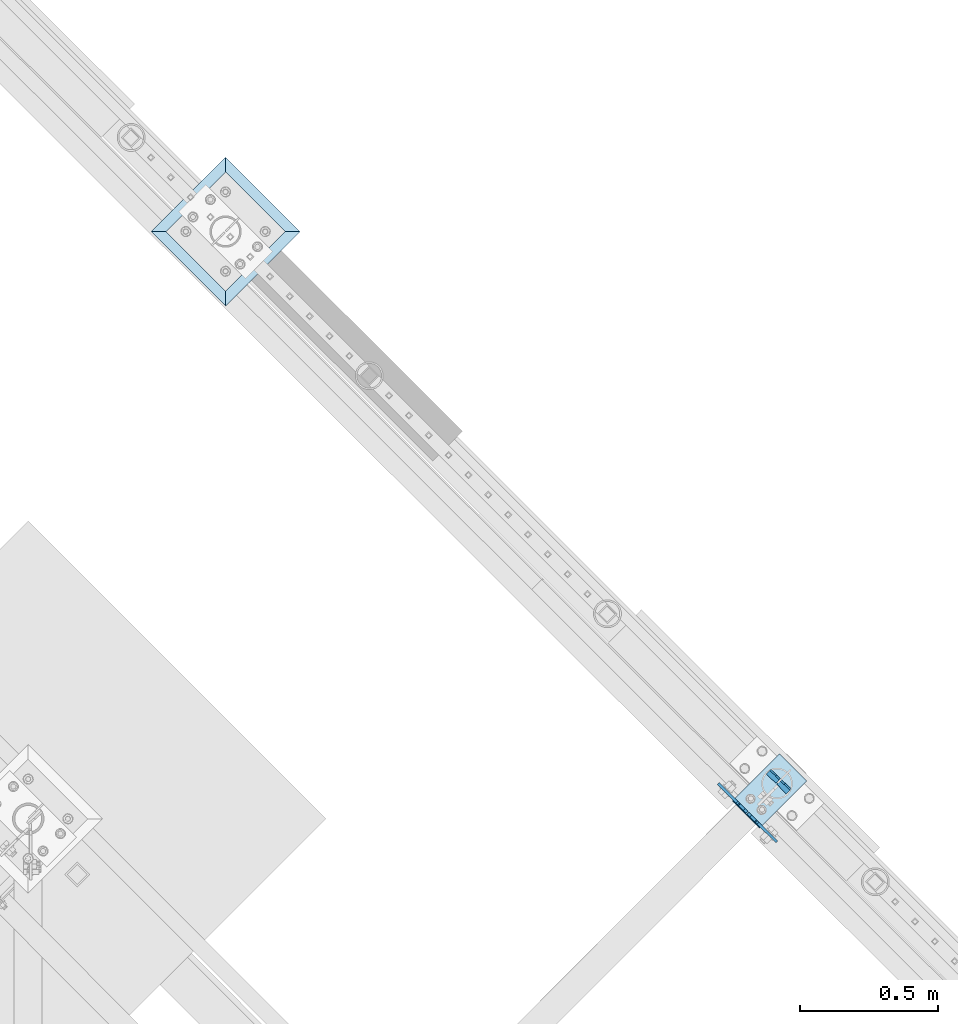
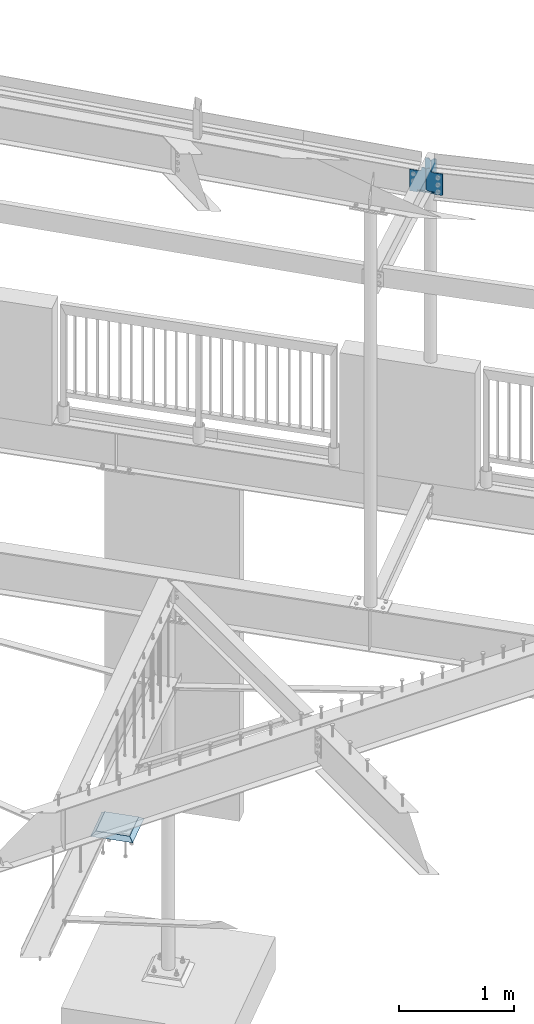
# One storey, part 927 of 975: 6 plates.
"""IFC2X3 building model written with IfcOpenShell, lengths in millimetres."""

from ifc_helpers import new_model, si_unit, frame, origin_with_axes, place, context, subcontext, project, spatial, faceted_brep, material, type_object, element, save


model = new_model("IFC2X3")

# Units and contexts
model_context = context("Model", 3, precision=1e-05, world=origin_with_axes())
body_context = subcontext(model_context, "Body", "Model", "MODEL_VIEW")
ifc_project = project(units=[si_unit("LENGTHUNIT", "METRE", prefix="MILLI"), si_unit("AREAUNIT", "SQUARE_METRE"), si_unit("VOLUMEUNIT", "CUBIC_METRE"), si_unit("MASSUNIT", "GRAM", prefix="KILO"), si_unit("TIMEUNIT", "SECOND"), si_unit("PLANEANGLEUNIT", "RADIAN"), si_unit("SOLIDANGLEUNIT", "STERADIAN"), si_unit("THERMODYNAMICTEMPERATUREUNIT", "DEGREE_CELSIUS"), si_unit("LUMINOUSINTENSITYUNIT", "LUMEN")], contexts=[model_context])

# Site, building, storey
site_placement = place(None, origin_with_axes())
site = spatial("IfcSite", under=ifc_project, at=site_placement, CompositionType="ELEMENT")
building_placement = place(site_placement, origin_with_axes())
building = spatial("IfcBuilding", under=site, at=building_placement, Name="Undefined", CompositionType="ELEMENT")
storey_placement = place(building_placement, origin_with_axes())
storey = spatial("IfcBuildingStorey", under=building, at=storey_placement, Name="Undefined", CompositionType="ELEMENT", Elevation=0.0)

# Plates
ifc_material_1 = material(Name="STEEL/A36")
plate_type_1 = type_object("IfcPlateType", PredefinedType="NOTDEFINED")
for number, where, z_axis, x_axis, name in (
    (1, (32591.3302326598, 16069.5507026305, 7309.03276785798), (-0.0530049208764358, -0.0531648081182575, -0.997178008953583), (-0.70817085185971, 0.706041106860141, 0.0), "PLATE"),
    (2, (32519.3800741067, 16141.2844790812, 7309.03276787573), (-0.0530049208764358, -0.0531648081182575, -0.997178008953583), (0.708170851859726, -0.706041106860125, 0.0), "PLATE"),
):
    element("IfcPlate", number, at=place(storey_placement, frame(where, z_axis=z_axis, x_axis=x_axis)), inside=storey, type_object=plate_type_1, material=ifc_material_1, Name=name, context=body_context, shape_type="Brep", body=[
        faceted_brep([(0.0, -3.17499999999927, 0.0), (0.0, -3.17499999999927, 241.300003051758), (0.0, 3.17499999999927, 241.300003051758), (0.0, 3.17499999999927, 0.0), (29.3687515258025, -3.17499999977736, 241.300003051745), (29.3687515257989, 3.17500000021391, 241.300003051743), (48.4187507628649, -3.17499999980646, 222.250003814686), (48.4187507628576, 3.17500000018481, 222.250003814683), (48.4187507629249, -3.17500000000291, 19.0499992370424), (48.4187507629249, 3.17499999998836, 19.0499992370424), (29.3687515258753, -3.17500000001746, -1.09139364212751e-11), (29.3687515258716, 3.17499999998836, -1.09139364212751e-11)], [[[0, 1, 2, 3]], [[1, 4, 5, 2]], [[4, 6, 7, 5]], [[6, 8, 9, 7]], [[8, 10, 11, 9]], [[10, 0, 3, 11]], [[5, 7, 9, 11, 3, 2]], [[10, 8, 6, 4, 1, 0]]]),
    ])
plate_type_2 = type_object("IfcPlateType", PredefinedType="NOTDEFINED")
plate_1_placement = place(storey_placement, frame((32407.3134475855, 16014.7135854311, 7080.11349690412), z_axis=(-2.16581264539855e-05, 2.16111261761398e-05, 0.999999999531942), x_axis=(0.707883857899947, -0.706328848900123, 3.05960000000052e-05)))
element("IfcPlate", 3, at=plate_1_placement, inside=storey, type_object=plate_type_2, material=ifc_material_1, Name="PLATE", context=body_context, shape_type="Brep", body=[
    faceted_brep([(-34.5983888467981, -4.76250000001892, -26.3990000251924), (-34.5986273310191, 4.76249999998981, -26.3990000178919), (-34.6003441032881, 4.76213454846584, -5.66041989399673), (-34.6001056190853, -4.76249999999709, -5.66041990304893), (-34.1171802591089, 4.76214664393774, -3.23034001559517), (-34.1169417745987, -4.76249999999709, -3.23034002464919), (-32.7408437240902, 4.7621811036297, -1.1701377786585), (-32.7406052387178, -4.76249999998981, -1.17013778771252), (-30.6808692796421, 4.762232681358, 0.206539671386963), (-30.6806307929801, -4.76249999998981, 0.206539662332943), (-28.250869391848, 4.7622935248728, 0.690105651907288), (-28.2506309036617, -4.76249999998981, 0.690105642853268), (-10.0594383498919, -4.76250000000437, 0.691610124605177), (-10.0596768494815, 4.76274900820863, 0.691610133659196), (-10.0051464618464, 4.76250000000437, -9.09494701772928e-12), (-10.0051464618537, -4.76250000000437, -1.36424205265939e-11), (-108.905647277928, -4.76249999998254, -26.3967266082927), (-108.898651122794, -4.76249999978609, 202.203277587798), (-108.898651122781, 4.76250000021537, 202.203277587801), (-108.905647277919, 4.76250000001892, -26.39672660829), (-19.9938152040522, -4.76249999982247, 202.200549600185), (-19.9938152040449, 4.76250000017899, 202.200549600188), (-12.3400994389212, -4.76249999982247, 203.722724270037), (-12.3400994389103, 4.76250000018626, 203.722724270041), (-5.85149921872289, -4.76249999982247, 208.057980654784), (-5.85149921871562, 4.76250000017899, 208.057980654788), (-1.51584521714176, -4.76249999982247, 214.546315195909), (-1.5158452171363, 4.76250000018626, 214.546315195913), (0.00679847374522069, -4.76249999981519, 222.19993766697), (0.00679847375249665, 4.76250000019354, 222.199937666973), (0.00738181583074038, -4.76249999980064, 241.265777587809), (0.00738181584165432, 4.76250000020809, 241.265777587812), (24.1347637180315, -4.76249999980791, 241.265777587813), (24.1347637180388, 4.76250000019354, 241.265777587817), (38.4218269785815, -4.76249999982247, 226.978277213038), (38.421826978587, 4.76250000017899, 226.978277213042), (38.4153197808555, -4.76250000001164, 14.2875003748195), (38.4153197808664, 4.76249999999709, 14.2875003748231), (24.1273822784515, -4.76250000001892, 2.5465851649642e-11), (24.1273822784588, 4.76249999998981, 2.91038304567337e-11), (0.0, -4.76250000000073, 0.0), (0.0, 4.76250000000073, 0.0)], [[[0, 1, 2, 3]], [[3, 2, 4, 5]], [[5, 4, 6, 7]], [[7, 6, 8, 9]], [[9, 8, 10, 11]], [[12, 13, 14, 15]], [[11, 10, 13, 12]], [[16, 17, 18, 19]], [[17, 20, 21, 18]], [[20, 22, 23, 21]], [[22, 24, 25, 23]], [[24, 26, 27, 25]], [[26, 28, 29, 27]], [[28, 30, 31, 29]], [[30, 32, 33, 31]], [[32, 34, 35, 33]], [[34, 36, 37, 35]], [[36, 38, 39, 37]], [[38, 40, 41, 39]], [[41, 40, 15, 14]], [[8, 6, 4, 2, 1, 19, 18, 21, 23, 25, 27, 29, 31, 33, 35, 37, 39, 41, 14, 13, 10]], [[16, 19, 1, 0]], [[40, 38, 36, 34, 32, 30, 28, 26, 24, 22, 20, 17, 16, 0, 3, 5, 7, 9, 11, 12, 15]]]),
])
plate_2_placement = place(storey_placement, frame((32465.0740351509, 15957.0798809336, 7080.1159934193), z_axis=(-2.16581264539855e-05, 2.16111261761398e-05, 0.999999999531942), x_axis=(-0.707883856901031, 0.706328849901238, -3.0595999985936e-05)))
element("IfcPlate", 4, at=plate_2_placement, inside=storey, type_object=plate_type_2, material=ifc_material_1, Name="PLATE", context=body_context, shape_type="Brep", body=[
    faceted_brep([(-36.2098246025562, -4.76249999996799, -24.8834229303829), (-36.2100631195481, 4.76250000004075, -24.8834229376844), (-36.208533789053, 4.76250000004075, -5.64782607582583), (-36.2082952720484, -4.76290589569544, -5.64782607350844), (-35.7249736378235, 4.76250000003347, -3.21781995024412), (-35.7247351211245, -4.76289378672664, -3.21781994792582), (-34.3482975392562, 4.76250000004075, -1.15783861272939), (-34.3480590234212, -4.7628593141344, -1.15783861041291), (-32.288092812656, 4.76250000003347, 0.218503160675937), (-32.2878542981125, -4.76280772608879, 0.218503162993329), (-29.8580082431617, 4.76250000002619, 0.701668948858241), (-29.8577697301407, -4.76274687644764, 0.701668951176543), (-9.99658407413153, -4.76224955062207, 0.700024822344858), (-9.99682257470158, 4.76250000001164, 0.700024820027465), (-9.9987271244463, 4.76250000001164, 1.72803993336856e-11), (-9.9987271244463, -4.76249999998981, 2.09183781407773e-11), (-108.898269653202, -4.76249999988795, -24.885646820032), (-108.905265807982, -4.76249999994616, 203.714355468712), (-108.90526580798, 4.7625000000553, 203.714355468707), (-108.8982696532, 4.7625000001135, -24.8856468200356), (-20.0062339673404, -4.76250000003347, 203.717070967217), (-20.0062339673404, 4.76249999996799, 203.717070967214), (-12.3526115948407, -4.76250000004075, 205.239714200417), (-12.3526115948389, 4.76249999996799, 205.239714200413), (-5.86427692852521, -4.76250000004802, 209.575367679925), (-5.8642769285234, 4.76249999995343, 209.575367679921), (-1.5290201668231, -4.7625000000553, 216.063967424602), (-1.52902016681946, 4.76249999994616, 216.063967424599), (-0.00684489417835721, -4.7625000000553, 223.717682880241), (-0.00684489417653822, 4.76249999994616, 223.717682880238), (-0.00738179776089964, -4.7625000000553, 241.265777587814), (-0.00738179775726167, 4.76249999994616, 241.265777587811), (24.1200008392152, -4.7625000000844, 241.265777587809), (24.120000839217, 4.76249999991705, 241.265777587805), (38.4079383415774, -4.76250000009168, 226.978277213027), (38.4079383415792, 4.7624999999025, 226.978277213024), (38.4144455389669, -4.76250000004802, 14.2875003747176), (38.4144455389669, 4.76249999995343, 14.287500374714), (24.1273822784515, -4.76250000001892, 2.5465851649642e-11), (24.1273822784588, 4.76249999998981, 2.91038304567337e-11), (0.0, -4.76250000000073, 0.0), (0.0, 4.76250000000073, 0.0)], [[[0, 1, 2, 3]], [[3, 2, 4, 5]], [[5, 4, 6, 7]], [[7, 6, 8, 9]], [[9, 8, 10, 11]], [[12, 13, 14, 15]], [[11, 10, 13, 12]], [[16, 17, 18, 19]], [[17, 20, 21, 18]], [[20, 22, 23, 21]], [[22, 24, 25, 23]], [[24, 26, 27, 25]], [[26, 28, 29, 27]], [[28, 30, 31, 29]], [[30, 32, 33, 31]], [[32, 34, 35, 33]], [[34, 36, 37, 35]], [[36, 38, 39, 37]], [[38, 40, 41, 39]], [[41, 40, 15, 14]], [[8, 6, 4, 2, 1, 19, 18, 21, 23, 25, 27, 29, 31, 33, 35, 37, 39, 41, 14, 13, 10]], [[16, 19, 1, 0]], [[40, 38, 36, 34, 32, 30, 28, 26, 24, 22, 20, 17, 16, 0, 3, 5, 7, 9, 11, 12, 15]]]),
])
plate_type_3 = type_object("IfcPlateType", PredefinedType="NOTDEFINED")
plate_3_placement = place(storey_placement, frame((32479.9770302729, 15930.125942555, 7069.25838507973), z_axis=(0.705117355306434, 0.70510531810105, -0.0750733350216762), x_axis=(-0.707106776641851, 0.707106776641851, -0.000113376999941856)))
element("IfcPlate", 5, at=plate_3_placement, inside=storey, type_object=plate_type_3, material=ifc_material_1, Name="PLATE", context=body_context, shape_type="Brep", body=[
    faceted_brep([(0.0, -6.34999999998763, -3.63797880709171e-12), (-2.80124368146062e-10, -6.34999999993306, 241.300003051925), (-2.92857293970883e-10, 6.35000000007312, 241.300003051925), (0.0, 6.34999999999491, 5.45696821063757e-12), (139.699996947658, -6.34999999996398, 241.300003051925), (139.699996947651, 6.3500000000422, 241.300003051932), (139.699996948082, -6.35000000003311, 8.73114913702011e-11), (139.699996948071, 6.34999999997308, 8.00355337560177e-11)], [[[0, 1, 2, 3]], [[1, 4, 5, 2]], [[4, 6, 7, 5]], [[6, 0, 3, 7]], [[5, 7, 3, 2]], [[6, 4, 1, 0]]]),
])
ifc_material_2 = material(Name="CONCRETE/GROUT")
plate_type_4 = type_object("IfcPlateType", PredefinedType="NOTDEFINED")
plate_4_placement = place(storey_placement, frame((30546.6750000001, 17820.1548163686, -285.749999999999), z_axis=(-0.707106781186601, 0.707106781186494, 2.36468622460961e-14), x_axis=(0.707106781186548, 0.707106781186548, 0.0)))
element("IfcPlate", 6, at=plate_4_placement, inside=storey, type_object=plate_type_4, material=ifc_material_2, Name="GROUT", context=body_context, shape_type="Brep", body=[
    faceted_brep([(38.1000000096292, -19.05, 342.899999985777), (0.0, 19.05, 381.0), (2.63382389675826e-07, 19.0500000000138, 0.0), (38.1000000092372, -19.05, 38.1000000116328), (342.899999988684, -19.05, 38.1000000120257), (381.0, 19.05, 0.0), (381.0, 19.05, 381.0), (342.899999989076, -19.05, 342.89999998617)], [[[0, 1, 2, 3]], [[4, 5, 6, 7]], [[4, 7, 0, 3]], [[5, 4, 3, 2]], [[6, 5, 2, 1]], [[7, 6, 1, 0]]]),
])

save(model, "model.ifc")
